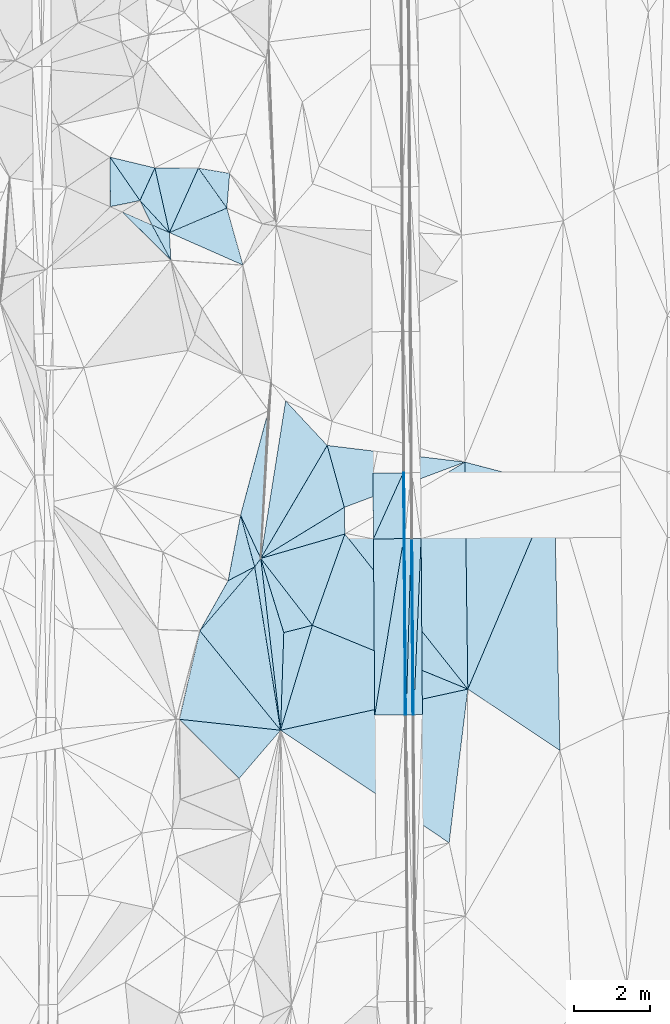
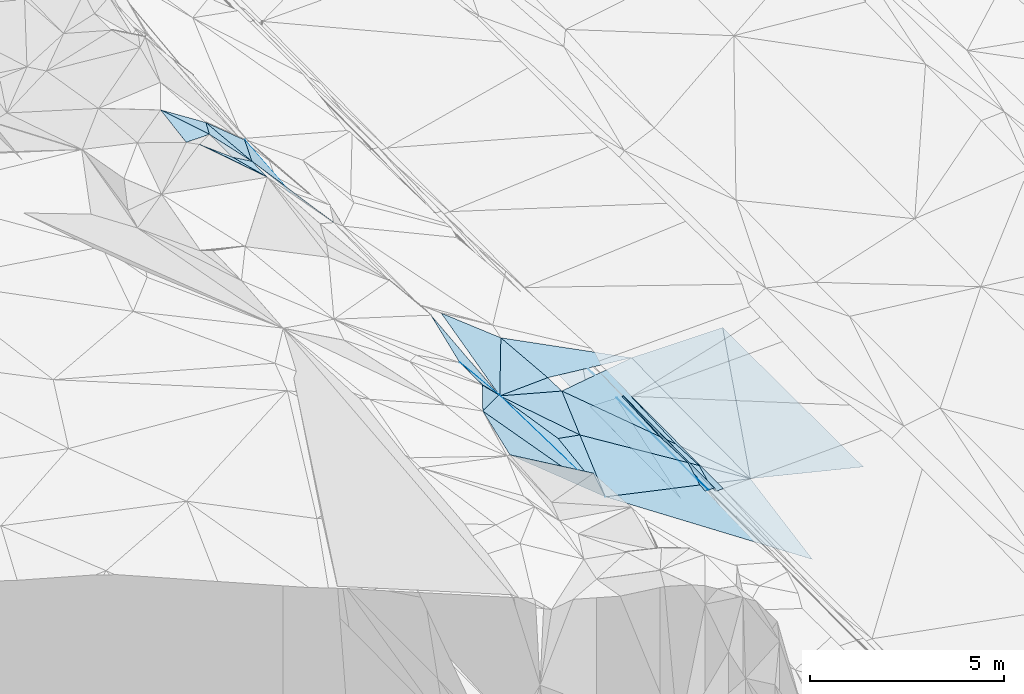
# One storey, part 54 of 275: 46 plates.
"""IFC2X3 building model written with IfcOpenShell, lengths in millimetres."""

from ifc_helpers import new_model, si_unit, frame, origin_with_axes, place, context, subcontext, project, spatial, polyline, outline, extrude, material, type_object, element, save


model = new_model("IFC2X3")

# Units and contexts
model_context = context("Model", 3, precision=1e-05, world=origin_with_axes())
body_context = subcontext(model_context, "Body", "Model", "MODEL_VIEW")
ifc_project = project(units=[si_unit("LENGTHUNIT", "METRE", prefix="MILLI"), si_unit("AREAUNIT", "SQUARE_METRE"), si_unit("VOLUMEUNIT", "CUBIC_METRE"), si_unit("MASSUNIT", "GRAM", prefix="KILO"), si_unit("TIMEUNIT", "SECOND"), si_unit("PLANEANGLEUNIT", "RADIAN"), si_unit("SOLIDANGLEUNIT", "STERADIAN"), si_unit("THERMODYNAMICTEMPERATUREUNIT", "DEGREE_CELSIUS"), si_unit("LUMINOUSINTENSITYUNIT", "LUMEN")], contexts=[model_context])

# Site, building, storey
site_placement = place(None, origin_with_axes())
site = spatial("IfcSite", under=ifc_project, at=site_placement, CompositionType="ELEMENT")
building_placement = place(site_placement, origin_with_axes())
building = spatial("IfcBuilding", under=site, at=building_placement, Name="Undefined", CompositionType="ELEMENT")
storey_placement = place(building_placement, origin_with_axes())
storey = spatial("IfcBuildingStorey", under=building, at=storey_placement, Name="Undefined", CompositionType="ELEMENT", Elevation=0.0)

# Plates
ifc_material = material()
plate_type_1 = type_object("IfcPlateType", PredefinedType="NOTDEFINED")
plate_1_placement = place(storey_placement, frame((-93950.5785130084, 36996.4624813921, 41676.0468128208), z_axis=(-0.970179685272548, -0.00209082154072468, -0.242377818188352), x_axis=(-0.0136848701070664, 0.998840273817399, 0.0461609329469833)))
element("IfcPlate", 1, at=plate_1_placement, inside=storey, type_object=plate_type_1, material=ifc_material, Name="00_PR", context=body_context, shape_type="SweptSolid", body=[
    extrude(outline(polyline([(0.0, 0.0), (4660.52099609375, -8.84756445884705e-09), (4655.595703125, 123.593780517578), (0.0, 0.0)])), frame((-8.85201319254618e-08, 2.18876761149539e-07, -0.5000001331573), z_axis=(0.0, 0.0, 1.0), x_axis=(1.0, 0.0, 0.0)), (0.0, 0.0, 1.0), 1.0),
])
plate_2_placement = place(storey_placement, frame((-93980.5688276247, 36995.7437087073, 41796.0467650642), z_axis=(-0.970155847921979, -0.00208608373127504, -0.242473254189927), x_axis=(-0.00725548811011348, 0.99976498987344, 0.0204284829501307)))
element("IfcPlate", 2, at=plate_2_placement, inside=storey, type_object=plate_type_1, material=ifc_material, Name="00_PR", context=body_context, shape_type="SweptSolid", body=[
    extrude(outline(polyline([(0.0, 0.0), (4656.92919921875, -3.04135028272867e-09), (-1.9504063129425, 123.677536010742), (0.0, 0.0)])), frame((-8.85201319254618e-08, 2.18876761149539e-07, -0.5000001331573), z_axis=(0.0, 0.0, 1.0), x_axis=(1.0, 0.0, 0.0)), (0.0, 0.0, 1.0), 1.0),
])
plate_type_2 = type_object("IfcPlateType", PredefinedType="NOTDEFINED")
plate_3_placement = place(storey_placement, frame((-94213.8776256981, 41650.2157978463, 41891.4022104386), z_axis=(-0.020135283573241, 0.0208413177685914, -0.99958001672157), x_axis=(0.0104989039006827, 0.999731988309625, 0.0206330939843829)))
element("IfcPlate", 3, at=plate_3_placement, inside=storey, type_object=plate_type_2, material=ifc_material, Name="00_PR", context=body_context, shape_type="SweptSolid", body=[
    extrude(outline(polyline([(0.0, 0.0), (1741.91040039063, 2.69210431724787e-09), (0.508228659629822, 30.0019760131836), (0.0, 0.0)])), frame((-8.85201319254618e-08, 2.18876761149539e-07, -0.5000001331573), z_axis=(0.0, 0.0, 1.0), x_axis=(1.0, 0.0, 0.0)), (0.0, 0.0, 1.0), 1.0),
])
plate_4_placement = place(storey_placement, frame((-94195.5894751698, 43391.6593004186, 41927.3432111175), z_axis=(-0.0201297745823609, 0.0208413569772079, -0.999580126860579), x_axis=(-0.0104989038900148, -0.999731988310175, -0.0206330939631766)))
element("IfcPlate", 4, at=plate_4_placement, inside=storey, type_object=plate_type_2, material=ifc_material, Name="00_PR", context=body_context, shape_type="SweptSolid", body=[
    extrude(outline(polyline([(0.0, 0.0), (1741.91040039063, 2.69210431724787e-09), (0.500202655792236, 30.0012283325195), (0.0, 0.0)])), frame((-8.85201319254618e-08, 2.18876761149539e-07, -0.5000001331573), z_axis=(0.0, 0.0, 1.0), x_axis=(1.0, 0.0, 0.0)), (0.0, 0.0, 1.0), 1.0),
])
plate_5_placement = place(storey_placement, frame((-94183.8780499656, 41650.4212178136, 41890.802205341), z_axis=(-0.0201311603663286, 0.0202781652050901, -0.999591682837658), x_axis=(0.00081387610926095, -0.999793629852607, -0.0202986529559961)))
element("IfcPlate", 5, at=plate_5_placement, inside=storey, type_object=plate_type_2, material=ifc_material, Name="00_PR", context=body_context, shape_type="SweptSolid", body=[
    extrude(outline(polyline([(0.0, 0.0), (4657.15625, -2.91038304567337e-11), (0.169063434004784, 30.0058040618896), (0.0, 0.0)])), frame((-8.85201319254618e-08, 2.18876761149539e-07, -0.5000001331573), z_axis=(0.0, 0.0, 1.0), x_axis=(1.0, 0.0, 0.0)), (0.0, 0.0, 1.0), 1.0),
])
plate_6_placement = place(storey_placement, frame((-94183.8780499656, 41650.4212178136, 41890.802205341), z_axis=(-0.0201474347669718, 0.0202780407636557, -0.999591357473192), x_axis=(0.00725548812216576, -0.999764989873477, -0.0204284829440498)))
element("IfcPlate", 6, at=plate_6_placement, inside=storey, type_object=plate_type_2, material=ifc_material, Name="00_PR", context=body_context, shape_type="SweptSolid", body=[
    extrude(outline(polyline([(0.0, 0.0), (4657.06005859375, -1.55559973791242e-08), (4657.0595703125, 30.0057888031006), (0.0, 0.0)])), frame((-8.85201319254618e-08, 2.18876761149539e-07, -0.5000001331573), z_axis=(0.0, 0.0, 1.0), x_axis=(1.0, 0.0, 0.0)), (0.0, 0.0, 1.0), 1.0),
])
plate_type_3 = type_object("IfcPlateType", PredefinedType="NOTDEFINED")
plate_7_placement = place(storey_placement, frame((-94225.5882216855, 43391.4616175226, 41927.9432097859), z_axis=(-0.0201291618125132, 0.020838557269471, -0.999580197570787), x_axis=(-0.411310993862948, -0.911432053981367, -0.0107180829806612)))
element("IfcPlate", 7, at=plate_7_placement, inside=storey, type_object=plate_type_3, material=ifc_material, Name="00_PR", context=body_context, shape_type="SweptSolid", body=[
    extrude(outline(polyline([(0.0, 0.0), (1916.48083496094, -5.3987605497241e-09), (333.668701171875, 727.270202636719), (0.0, 0.0)])), frame((-8.85201319254618e-08, 2.18876761149539e-07, -0.5000001331573), z_axis=(0.0, 0.0, 1.0), x_axis=(1.0, 0.0, 0.0)), (0.0, 0.0, 1.0), 1.0),
])
plate_8_placement = place(storey_placement, frame((-94980.0641760851, 36988.1104912917, 41812.2682041241), z_axis=(-0.0201474347669718, 0.0202780407636557, -0.999591357473192), x_axis=(0.162145343856178, 0.986624766843307, 0.0167468479766436)))
element("IfcPlate", 8, at=plate_8_placement, inside=storey, type_object=plate_type_3, material=ifc_material, Name="00_PR", context=body_context, shape_type="SweptSolid", body=[
    extrude(outline(polyline([(0.0, 0.0), (4725.30712890625, -1.06228981167078e-08), (135.478302001953, 788.607238769531), (0.0, 0.0)])), frame((-8.85201319254618e-08, 2.18876761149539e-07, -0.5000001331573), z_axis=(0.0, 0.0, 1.0), x_axis=(1.0, 0.0, 0.0)), (0.0, 0.0, 1.0), 1.0),
])
plate_9_placement = place(storey_placement, frame((-95013.8578508624, 41644.7195649811, 41907.4022094832), z_axis=(-0.020135283573241, 0.0208413177685914, -0.99958001672157), x_axis=(0.411310993878784, 0.911432053974247, 0.0107180829784441)))
element("IfcPlate", 9, at=plate_9_placement, inside=storey, type_object=plate_type_3, material=ifc_material, Name="00_PR", context=body_context, shape_type="SweptSolid", body=[
    extrude(outline(polyline([(0.0, 0.0), (1916.48083496094, -5.3987605497241e-09), (333.878601074219, 727.17236328125), (0.0, 0.0)])), frame((-8.85201319254618e-08, 2.18876761149539e-07, -0.5000001331573), z_axis=(0.0, 0.0, 1.0), x_axis=(1.0, 0.0, 0.0)), (0.0, 0.0, 1.0), 1.0),
])
plate_10_placement = place(storey_placement, frame((-94213.8776239783, 41650.2155149351, 41891.4022045246), z_axis=(-0.0201316304963867, 0.0202754497270247, -0.999591728453134), x_axis=(-0.162145343868325, -0.986624766841396, -0.01674684797159)))
element("IfcPlate", 10, at=plate_10_placement, inside=storey, type_object=plate_type_3, material=ifc_material, Name="00_PR", context=body_context, shape_type="SweptSolid", body=[
    extrude(outline(polyline([(0.0, 0.0), (4725.30712890625, -1.06228981167078e-08), (134.867828369141, 788.711120605469), (0.0, 0.0)])), frame((-8.85201319254618e-08, 2.18876761149539e-07, -0.5000001331573), z_axis=(0.0, 0.0, 1.0), x_axis=(1.0, 0.0, 0.0)), (0.0, 0.0, 1.0), 1.0),
])
plate_type_4 = type_object("IfcPlateType", PredefinedType="NOTDEFINED")
plate_11_placement = place(storey_placement, frame((-99602.1503594597, 39215.5463173642, 44839.7314416083), z_axis=(-0.772565921785493, 0.338620914935313, -0.537101268350861), x_axis=(0.485372854095596, 0.860320502442921, -0.155762080056269)))
element("IfcPlate", 11, at=plate_11_placement, inside=storey, type_object=plate_type_4, material=ifc_material, Name="00", context=body_context, shape_type="SweptSolid", body=[
    extrude(outline(polyline([(0.0, 0.0), (1540.8115234375, 1.07684172689915e-09), (2317.35034179688, 794.976318359375), (0.0, 0.0)])), frame((-8.85201319254618e-08, 2.18876761149539e-07, -0.5000001331573), z_axis=(0.0, 0.0, 1.0), x_axis=(1.0, 0.0, 0.0)), (0.0, 0.0, 1.0), 1.0),
])
plate_type_5 = type_object("IfcPlateType", PredefinedType="NOTDEFINED")
plate_12_placement = place(storey_placement, frame((-93753.8615539523, 41653.3765346723, 41778.3023714992), z_axis=(0.0324702506987195, 0.0206546735907928, -0.999259259290811), x_axis=(0.00725548812216576, -0.999764989873477, -0.0204284829440498)))
element("IfcPlate", 12, at=plate_12_placement, inside=storey, type_object=plate_type_5, material=ifc_material, Name="00_PR", context=body_context, shape_type="SweptSolid", body=[
    extrude(outline(polyline([(0.0, 0.0), (4656.728515625, 3.33238858729601e-09), (4656.4814453125, 230.128311157227), (0.0, 0.0)])), frame((-8.85201319254618e-08, 2.18876761149539e-07, -0.5000001331573), z_axis=(0.0, 0.0, 1.0), x_axis=(1.0, 0.0, 0.0)), (0.0, 0.0, 1.0), 1.0),
])
plate_13_placement = place(storey_placement, frame((-93983.8786685902, 41652.6155986422, 41770.8023725597), z_axis=(0.0325137458013369, 0.0206528108191279, -0.999257883501169), x_axis=(0.999463375983165, 0.00330638811473462, 0.0325887690158541)))
element("IfcPlate", 13, at=plate_13_placement, inside=storey, type_object=plate_type_5, material=ifc_material, Name="00_PR", context=body_context, shape_type="SweptSolid", body=[
    extrude(outline(polyline([(0.0, 0.0), (230.140640258789, -1.06228981167078e-09), (15.2880506515503, 4657.2109375), (0.0, 0.0)])), frame((-8.85201319254618e-08, 2.18876761149539e-07, -0.5000001331573), z_axis=(0.0, 0.0, 1.0), x_axis=(1.0, 0.0, 0.0)), (0.0, 0.0, 1.0), 1.0),
])
plate_type_6 = type_object("IfcPlateType", PredefinedType="NOTDEFINED")
plate_14_placement = place(storey_placement, frame((-94013.8721249891, 41651.5898474304, 41890.8021053352), z_axis=(-0.00015613799379114, 0.0204278877646966, -0.999791316736848), x_axis=(0.00725548812216576, -0.999764989873477, -0.0204284829440498)))
element("IfcPlate", 14, at=plate_14_placement, inside=storey, type_object=plate_type_6, material=ifc_material, Name="00_PR", context=body_context, shape_type="SweptSolid", body=[
    extrude(outline(polyline([(0.0, 0.0), (4656.92919921875, -3.04135028272867e-09), (4656.9951171875, 169.999923706055), (0.0, 0.0)])), frame((-8.85201319254618e-08, 2.18876761149539e-07, -0.5000001331573), z_axis=(0.0, 0.0, 1.0), x_axis=(1.0, 0.0, 0.0)), (0.0, 0.0, 1.0), 1.0),
])
plate_15_placement = place(storey_placement, frame((-94150.0787969721, 36994.4556287744, 41795.6681059385), z_axis=(-0.000140417984787431, 0.0204274278473883, -0.99979132846526), x_axis=(-0.00725548811011348, 0.99976498987344, 0.0204284829501307)))
element("IfcPlate", 15, at=plate_15_placement, inside=storey, type_object=plate_type_6, material=ifc_material, Name="00_PR", context=body_context, shape_type="SweptSolid", body=[
    extrude(outline(polyline([(0.0, 0.0), (4657.06005859375, -1.55559973791242e-08), (4656.9951171875, 169.999923706055), (0.0, 0.0)])), frame((-8.85201319254618e-08, 2.18876761149539e-07, -0.5000001331573), z_axis=(0.0, 0.0, 1.0), x_axis=(1.0, 0.0, 0.0)), (0.0, 0.0, 1.0), 1.0),
])
plate_type_7 = type_object("IfcPlateType", PredefinedType="NOTDEFINED")
plate_16_placement = place(storey_placement, frame((-100405.86991803, 49739.0135240849, 46609.6032710821), z_axis=(-0.608535526301397, 0.0116429874146828, -0.793441210218592), x_axis=(-0.598082811224722, 0.650415691934022, 0.468248201922358)))
element("IfcPlate", 16, at=plate_16_placement, inside=storey, type_object=plate_type_7, material=ifc_material, Name="00", context=body_context, shape_type="SweptSolid", body=[
    extrude(outline(polyline([(0.0, 0.0), (1302.72790527344, 5.82076609134674e-11), (1492.40686035156, 974.228881835938), (0.0, 0.0)])), frame((-8.85201319254618e-08, 2.18876761149539e-07, -0.5000001331573), z_axis=(0.0, 0.0, 1.0), x_axis=(1.0, 0.0, 0.0)), (0.0, 0.0, 1.0), 1.0),
])
plate_type_8 = type_object("IfcPlateType", PredefinedType="NOTDEFINED")
plate_17_placement = place(storey_placement, frame((-98525.9534439738, 42271.4719195884, 44139.6603795784), z_axis=(-0.732753729225391, -0.0415330979365877, -0.679225274914054), x_axis=(0.25769535006146, -0.940734641474832, -0.220480023779757)))
element("IfcPlate", 17, at=plate_17_placement, inside=storey, type_object=plate_type_8, material=ifc_material, Name="00", context=body_context, shape_type="SweptSolid", body=[
    extrude(outline(polyline([(0.0, 0.0), (1451.37866210938, -2.2846506908536e-09), (1441.93933105469, 1111.26550292969), (0.0, 0.0)])), frame((-8.85201319254618e-08, 2.18876761149539e-07, -0.5000001331573), z_axis=(0.0, 0.0, 1.0), x_axis=(1.0, 0.0, 0.0)), (0.0, 0.0, 1.0), 1.0),
])
plate_type_9 = type_object("IfcPlateType", PredefinedType="NOTDEFINED")
plate_18_placement = place(storey_placement, frame((-100405.88402384, 49739.0082591575, 46609.6144608093), z_axis=(-0.636753251418782, 0.00111473213475843, -0.77106682860818), x_axis=(-0.215741597249858, 0.959800922046216, 0.179548748966161)))
element("IfcPlate", 18, at=plate_18_placement, inside=storey, type_object=plate_type_9, material=ifc_material, Name="00", context=body_context, shape_type="SweptSolid", body=[
    extrude(outline(polyline([(0.0, 0.0), (1782.24572753906, -2.40106601268053e-09), (1358.39855957031, 1430.47314453125), (0.0, 0.0)])), frame((-8.85201319254618e-08, 2.18876761149539e-07, -0.5000001331573), z_axis=(0.0, 0.0, 1.0), x_axis=(1.0, 0.0, 0.0)), (0.0, 0.0, 1.0), 1.0),
])
plate_type_10 = type_object("IfcPlateType", PredefinedType="NOTDEFINED")
plate_19_placement = place(storey_placement, frame((-97468.2220157343, 36587.781176388, 42985.5196820596), z_axis=(-0.259570074999627, 0.0993513338899529, -0.960600171048796), x_axis=(-0.113523928559308, 0.984658279731703, 0.132515620966985)))
element("IfcPlate", 19, at=plate_19_placement, inside=storey, type_object=plate_type_10, material=ifc_material, Name="00", context=body_context, shape_type="SweptSolid", body=[
    extrude(outline(polyline([(0.0, 0.0), (4610.77734375, -1.37370079755783e-08), (2563.76416015625, 391.875732421875), (0.0, 0.0)])), frame((-8.85201319254618e-08, 2.18876761149539e-07, -0.5000001331573), z_axis=(0.0, 0.0, 1.0), x_axis=(1.0, 0.0, 0.0)), (0.0, 0.0, 1.0), 1.0),
])
plate_type_11 = type_object("IfcPlateType", PredefinedType="NOTDEFINED")
plate_20_placement = place(storey_placement, frame((-101184.948108172, 50586.2873270622, 47219.5645824686), z_axis=(-0.486582377466823, -0.070098330524117, -0.870817899446529), x_axis=(-0.550702514058618, 0.798412240717518, 0.243443288841468)))
element("IfcPlate", 20, at=plate_20_placement, inside=storey, type_object=plate_type_11, material=ifc_material, Name="00", context=body_context, shape_type="SweptSolid", body=[
    extrude(outline(polyline([(0.0, 0.0), (1437.70654296875, 6.28642737865448e-09), (401.333648681641, 907.76171875), (0.0, 0.0)])), frame((-8.85201319254618e-08, 2.18876761149539e-07, -0.5000001331573), z_axis=(0.0, 0.0, 1.0), x_axis=(1.0, 0.0, 0.0)), (0.0, 0.0, 1.0), 1.0),
])
plate_type_12 = type_object("IfcPlateType", PredefinedType="NOTDEFINED")
plate_21_placement = place(storey_placement, frame((-100866.297406921, 49939.9729684774, 46779.5271561575), z_axis=(-0.316385608843126, 0.074878604908276, -0.945670841806997), x_axis=(0.86823434398444, -0.378772150786415, -0.320469626820612)))
element("IfcPlate", 21, at=plate_21_placement, inside=storey, type_object=plate_type_12, material=ifc_material, Name="00", context=body_context, shape_type="SweptSolid", body=[
    extrude(outline(polyline([(0.0, 0.0), (530.471496582031, 1.74622982740402e-10), (860.55517578125, 652.644409179688), (0.0, 0.0)])), frame((-8.85201319254618e-08, 2.18876761149539e-07, -0.5000001331573), z_axis=(0.0, 0.0, 1.0), x_axis=(1.0, 0.0, 0.0)), (0.0, 0.0, 1.0), 1.0),
])
plate_type_13 = type_object("IfcPlateType", PredefinedType="NOTDEFINED")
plate_22_placement = place(storey_placement, frame((-101655.657473941, 50290.7311582777, 47249.5780910048), z_axis=(-0.53241500267624, -0.067335114786549, -0.843801070894047), x_axis=(0.80264765384784, -0.35678375573582, -0.477977086705631)))
element("IfcPlate", 22, at=plate_22_placement, inside=storey, type_object=plate_type_13, material=ifc_material, Name="00", context=body_context, shape_type="SweptSolid", body=[
    extrude(outline(polyline([(0.0, 0.0), (983.310729980469, -4.40923031419516e-09), (1828.61828613281, 672.276062011719), (0.0, 0.0)])), frame((-8.85201319254618e-08, 2.18876761149539e-07, -0.5000001331573), z_axis=(0.0, 0.0, 1.0), x_axis=(1.0, 0.0, 0.0)), (0.0, 0.0, 1.0), 1.0),
])
plate_type_14 = type_object("IfcPlateType", PredefinedType="NOTDEFINED")
plate_23_placement = place(storey_placement, frame((-100405.604317466, 49739.2750519236, 46609.579243459), z_axis=(-0.0773353083120374, 0.534698628494853, -0.841496658801451), x_axis=(-0.868234343983698, 0.378772150780406, 0.320469626829725)))
element("IfcPlate", 23, at=plate_23_placement, inside=storey, type_object=plate_type_14, material=ifc_material, Name="00", context=body_context, shape_type="SweptSolid", body=[
    extrude(outline(polyline([(0.0, 0.0), (530.471496582031, 1.74622982740402e-10), (1192.90100097656, 523.533264160156), (0.0, 0.0)])), frame((-8.85201319254618e-08, 2.18876761149539e-07, -0.5000001331573), z_axis=(0.0, 0.0, 1.0), x_axis=(1.0, 0.0, 0.0)), (0.0, 0.0, 1.0), 1.0),
])
plate_type_15 = type_object("IfcPlateType", PredefinedType="NOTDEFINED")
plate_24_placement = place(storey_placement, frame((-98525.976075918, 42271.4593291351, 44139.6876463612), z_axis=(-0.778016569987856, -0.0667130044341407, -0.624691597401232), x_axis=(0.388660819200202, -0.832338106926882, -0.39516584287613)))
element("IfcPlate", 24, at=plate_24_placement, inside=storey, type_object=plate_type_15, material=ifc_material, Name="00", context=body_context, shape_type="SweptSolid", body=[
    extrude(outline(polyline([(0.0, 0.0), (1374.10656738281, 5.16592990607023e-10), (1408.26049804688, 351.144592285156), (0.0, 0.0)])), frame((-8.85201319254618e-08, 2.18876761149539e-07, -0.5000001331573), z_axis=(0.0, 0.0, 1.0), x_axis=(1.0, 0.0, 0.0)), (0.0, 0.0, 1.0), 1.0),
])
plate_type_16 = type_object("IfcPlateType", PredefinedType="NOTDEFINED")
plate_25_placement = place(storey_placement, frame((-101976.544969999, 51734.2893371752, 47569.5157652047), z_axis=(-0.183133861079745, 0.168975512687857, -0.96845715704821), x_axis=(0.550702514081441, -0.798412240700273, -0.243443288846396)))
element("IfcPlate", 25, at=plate_25_placement, inside=storey, type_object=plate_type_16, material=ifc_material, Name="00", context=body_context, shape_type="SweptSolid", body=[
    extrude(outline(polyline([(0.0, 0.0), (1437.70654296875, 6.28642737865448e-09), (1105.44116210938, 735.730773925781), (0.0, 0.0)])), frame((-8.85201319254618e-08, 2.18876761149539e-07, -0.5000001331573), z_axis=(0.0, 0.0, 1.0), x_axis=(1.0, 0.0, 0.0)), (0.0, 0.0, 1.0), 1.0),
])
plate_type_17 = type_object("IfcPlateType", PredefinedType="NOTDEFINED")
plate_26_placement = place(storey_placement, frame((-96626.7172636025, 39360.8251726172, 42959.5456123844), z_axis=(-0.417322743732877, 0.00521624135214632, -0.908743373229989), x_axis=(-0.587891846576746, 0.760997636621141, 0.274346083962614)))
element("IfcPlate", 26, at=plate_26_placement, inside=storey, type_object=plate_type_17, material=ifc_material, Name="00", context=body_context, shape_type="SweptSolid", body=[
    extrude(outline(polyline([(0.0, 0.0), (2321.884765625, 8.87666828930378e-10), (1227.70092773438, 2279.11181640625), (0.0, 0.0)])), frame((-8.85201319254618e-08, 2.18876761149539e-07, -0.5000001331573), z_axis=(0.0, 0.0, 1.0), x_axis=(1.0, 0.0, 0.0)), (0.0, 0.0, 1.0), 1.0),
])
plate_type_18 = type_object("IfcPlateType", PredefinedType="NOTDEFINED")
plate_27_placement = place(storey_placement, frame((-99640.0886888829, 51444.3736954838, 45979.704746539), z_axis=(-0.79499853982599, 0.138894643180465, -0.590496062451152), x_axis=(0.415598475119519, -0.584372363804399, -0.696984108785838)))
element("IfcPlate", 27, at=plate_27_placement, inside=storey, type_object=plate_type_18, material=ifc_material, Name="00", context=body_context, shape_type="SweptSolid", body=[
    extrude(outline(polyline([(0.0, 0.0), (1807.78869628906, 6.05359673500061e-09), (239.131927490234, 1958.14099121094), (0.0, 0.0)])), frame((-8.85201319254618e-08, 2.18876761149539e-07, -0.5000001331573), z_axis=(0.0, 0.0, 1.0), x_axis=(1.0, 0.0, 0.0)), (0.0, 0.0, 1.0), 1.0),
])
plate_type_19 = type_object("IfcPlateType", PredefinedType="NOTDEFINED")
plate_28_placement = place(storey_placement, frame((-98888.8039558156, 50387.8889992374, 44719.7399294807), z_axis=(-0.853988008944963, 0.0130158957795944, -0.520129855935297), x_axis=(-0.415598475138861, 0.584372363799542, 0.696984108778377)))
element("IfcPlate", 28, at=plate_28_placement, inside=storey, type_object=plate_type_19, material=ifc_material, Name="00", context=body_context, shape_type="SweptSolid", body=[
    extrude(outline(polyline([(0.0, 0.0), (1807.78869628906, 6.05359673500061e-09), (436.057586669922, 818.262634277344), (0.0, 0.0)])), frame((-8.85201319254618e-08, 2.18876761149539e-07, -0.5000001331573), z_axis=(0.0, 0.0, 1.0), x_axis=(1.0, 0.0, 0.0)), (0.0, 0.0, 1.0), 1.0),
])
plate_type_20 = type_object("IfcPlateType", PredefinedType="NOTDEFINED")
plate_29_placement = place(storey_placement, frame((-97991.9286828822, 41127.7647350316, 43596.704135629), z_axis=(-0.806038825620768, -0.0132974486103588, -0.591713266246708), x_axis=(0.11352392816766, -0.984658279787137, -0.132515620890593)))
element("IfcPlate", 29, at=plate_29_placement, inside=storey, type_object=plate_type_20, material=ifc_material, Name="00", context=body_context, shape_type="SweptSolid", body=[
    extrude(outline(polyline([(0.0, 0.0), (4610.77734375, -1.37370079755783e-08), (170.520278930664, 308.855682373047), (0.0, 0.0)])), frame((-8.85201319254618e-08, 2.18876761149539e-07, -0.5000001331573), z_axis=(0.0, 0.0, 1.0), x_axis=(1.0, 0.0, 0.0)), (0.0, 0.0, 1.0), 1.0),
])
plate_type_21 = type_object("IfcPlateType", PredefinedType="NOTDEFINED")
plate_30_placement = place(storey_placement, frame((-97991.852256333, 41127.7981745605, 43596.6223440139), z_axis=(-0.653189580687692, 0.0535816736762087, -0.755296217339326), x_axis=(-0.38866081919298, 0.832338106926508, 0.395165842884021)))
element("IfcPlate", 30, at=plate_30_placement, inside=storey, type_object=plate_type_21, material=ifc_material, Name="00", context=body_context, shape_type="SweptSolid", body=[
    extrude(outline(polyline([(0.0, 0.0), (1374.10656738281, 5.16592990607023e-10), (3214.4296875, 2232.44506835938), (0.0, 0.0)])), frame((-8.85201319254618e-08, 2.18876761149539e-07, -0.5000001331573), z_axis=(0.0, 0.0, 1.0), x_axis=(1.0, 0.0, 0.0)), (0.0, 0.0, 1.0), 1.0),
])
plate_type_22 = type_object("IfcPlateType", PredefinedType="NOTDEFINED")
plate_31_placement = place(storey_placement, frame((-96235.5825426731, 44114.9416529231, 42999.5331166571), z_axis=(-0.357199911746024, 0.0233822920339932, -0.933735236278395), x_axis=(-0.49944090563772, -0.849547667654879, 0.169786754954352)))
element("IfcPlate", 31, at=plate_31_placement, inside=storey, type_object=plate_type_22, material=ifc_material, Name="00", context=body_context, shape_type="SweptSolid", body=[
    extrude(outline(polyline([(0.0, 0.0), (3516.17529296875, -1.58906914293766e-08), (-373.522338867188, 1629.19641113281), (0.0, 0.0)])), frame((-8.85201319254618e-08, 2.18876761149539e-07, -0.5000001331573), z_axis=(0.0, 0.0, 1.0), x_axis=(1.0, 0.0, 0.0)), (0.0, 0.0, 1.0), 1.0),
])
plate_type_23 = type_object("IfcPlateType", PredefinedType="NOTDEFINED")
plate_32_placement = place(storey_placement, frame((-98151.8815449293, 40906.1576437955, 43819.6070616894), z_axis=(-0.61601635832866, 0.0542730650618408, -0.785861489500719), x_axis=(0.153557317141866, -0.970211857646001, -0.187374228845079)))
element("IfcPlate", 32, at=plate_32_placement, inside=storey, type_object=plate_type_23, material=ifc_material, Name="00", context=body_context, shape_type="SweptSolid", body=[
    extrude(outline(polyline([(0.0, 0.0), (4450.98583984375, -3.94356902688742e-09), (1226.57995605469, 2120.7548828125), (0.0, 0.0)])), frame((-8.85201319254618e-08, 2.18876761149539e-07, -0.5000001331573), z_axis=(0.0, 0.0, 1.0), x_axis=(1.0, 0.0, 0.0)), (0.0, 0.0, 1.0), 1.0),
])
plate_type_24 = type_object("IfcPlateType", PredefinedType="NOTDEFINED")
plate_33_placement = place(storey_placement, frame((-99602.0686675432, 39215.4085602881, 44839.6047342585), z_axis=(-0.60918171727886, 0.0631067917521714, -0.790515760859913), x_axis=(0.55286136695901, -0.680856163662049, -0.480394830662874)))
element("IfcPlate", 33, at=plate_33_placement, inside=storey, type_object=plate_type_24, material=ifc_material, Name="00", context=body_context, shape_type="SweptSolid", body=[
    extrude(outline(polyline([(0.0, 0.0), (3859.32543945313, -2.81579559668899e-09), (1182.62634277344, 2101.0224609375), (0.0, 0.0)])), frame((-8.85201319254618e-08, 2.18876761149539e-07, -0.5000001331573), z_axis=(0.0, 0.0, 1.0), x_axis=(1.0, 0.0, 0.0)), (0.0, 0.0, 1.0), 1.0),
])
plate_type_25 = type_object("IfcPlateType", PredefinedType="NOTDEFINED")
plate_34_placement = place(storey_placement, frame((-95784.965398504, 42477.2993653637, 42579.5448268288), z_axis=(-0.413812237946844, -0.00933834867042202, -0.910314356126242), x_axis=(0.0225608886650078, -0.999745470758755, -4.4947101919241e-11)))
element("IfcPlate", 34, at=plate_34_placement, inside=storey, type_object=plate_type_25, material=ifc_material, Name="00", context=body_context, shape_type="SweptSolid", body=[
    extrude(outline(polyline([(0.0, 0.0), (703.846557617188, -1.94995664060116e-09), (1299.40246582031, 2457.0107421875), (0.0, 0.0)])), frame((-8.85201319254618e-08, 2.18876761149539e-07, -0.5000001331573), z_axis=(0.0, 0.0, 1.0), x_axis=(1.0, 0.0, 0.0)), (0.0, 0.0, 1.0), 1.0),
])
plate_type_26 = type_object("IfcPlateType", PredefinedType="NOTDEFINED")
plate_35_placement = place(storey_placement, frame((-98463.2340263936, 48881.2225842295, 44519.6764743021), z_axis=(-0.751912890944827, -0.126477038896554, -0.647016663667136), x_axis=(-0.652007113352726, 0.287866662631712, 0.70144102295398)))
element("IfcPlate", 35, at=plate_35_placement, inside=storey, type_object=plate_type_26, material=ifc_material, Name="00", context=body_context, shape_type="SweptSolid", body=[
    extrude(outline(polyline([(0.0, 0.0), (2979.58056640625, -1.10630935523659e-08), (851.428588867188, 1328.89782714844), (0.0, 0.0)])), frame((-8.85201319254618e-08, 2.18876761149539e-07, -0.5000001331573), z_axis=(0.0, 0.0, 1.0), x_axis=(1.0, 0.0, 0.0)), (0.0, 0.0, 1.0), 1.0),
])
plate_type_27 = type_object("IfcPlateType", PredefinedType="NOTDEFINED")
plate_36_placement = place(storey_placement, frame((-96235.6365314203, 44114.9787802046, 42999.5600758926), z_axis=(-0.46517720503653, 0.0976370485516825, -0.879816557393937), x_axis=(0.257562152640402, -0.935969635726211, -0.240047033986645)))
element("IfcPlate", 36, at=plate_36_placement, inside=storey, type_object=plate_type_27, material=ifc_material, Name="00", context=body_context, shape_type="SweptSolid", body=[
    extrude(outline(polyline([(0.0, 0.0), (1749.65710449219, 2.56113708019257e-09), (2200.27099609375, 2742.68041992188), (0.0, 0.0)])), frame((-8.85201319254618e-08, 2.18876761149539e-07, -0.5000001331573), z_axis=(0.0, 0.0, 1.0), x_axis=(1.0, 0.0, 0.0)), (0.0, 0.0, 1.0), 1.0),
])
plate_type_28 = type_object("IfcPlateType", PredefinedType="NOTDEFINED")
plate_37_placement = place(storey_placement, frame((-96626.6898055749, 39360.8732148627, 42959.5367352923), z_axis=(-0.362409346733524, 0.101298087291079, -0.926497794337013), x_axis=(0.85781407129879, -0.352449672402437, -0.374077862891149)))
element("IfcPlate", 37, at=plate_37_placement, inside=storey, type_object=plate_type_28, material=ifc_material, Name="00", context=body_context, shape_type="SweptSolid", body=[
    extrude(outline(polyline([(0.0, 0.0), (4787.7734375, 3.4315462471568e-08), (245.726760864258, 2887.66186523438), (0.0, 0.0)])), frame((-8.85201319254618e-08, 2.18876761149539e-07, -0.5000001331573), z_axis=(0.0, 0.0, 1.0), x_axis=(1.0, 0.0, 0.0)), (0.0, 0.0, 1.0), 1.0),
])
plate_type_29 = type_object("IfcPlateType", PredefinedType="NOTDEFINED")
plate_38_placement = place(storey_placement, frame((-92596.8487141097, 43674.7009432283, 41362.5447917376), z_axis=(-0.394445886324465, 0.124941084995967, -0.910385724867069), x_axis=(-0.881556566504766, -0.331079865490798, 0.336517670737993)))
element("IfcPlate", 38, at=plate_38_placement, inside=storey, type_object=plate_type_29, material=ifc_material, Name="00", context=body_context, shape_type="SweptSolid", body=[
    extrude(outline(polyline([(0.0, 0.0), (3616.45190429688, -1.58761395141482e-08), (3612.87377929688, 1749.65344238281), (0.0, 0.0)])), frame((-8.85201319254618e-08, 2.18876761149539e-07, -0.5000001331573), z_axis=(0.0, 0.0, 1.0), x_axis=(1.0, 0.0, 0.0)), (0.0, 0.0, 1.0), 1.0),
])
plate_type_30 = type_object("IfcPlateType", PredefinedType="NOTDEFINED")
plate_39_placement = place(storey_placement, frame((-95769.0646991747, 41773.6492267406, 42579.5358831444), z_axis=(-0.371218550944487, 0.0252325595276215, -0.928202620861609), x_axis=(0.814787695386717, 0.488272950370836, -0.312586847744049)))
element("IfcPlate", 39, at=plate_39_placement, inside=storey, type_object=plate_type_30, material=ifc_material, Name="00", context=body_context, shape_type="SweptSolid", body=[
    extrude(outline(polyline([(0.0, 0.0), (3893.31811523438, -6.95581547915936e-09), (1086.57531738281, 5308.57470703125), (0.0, 0.0)])), frame((-8.85201319254618e-08, 2.18876761149539e-07, -0.5000001331573), z_axis=(0.0, 0.0, 1.0), x_axis=(1.0, 0.0, 0.0)), (0.0, 0.0, 1.0), 1.0),
])
plate_type_31 = type_object("IfcPlateType", PredefinedType="NOTDEFINED")
plate_40_placement = place(storey_placement, frame((-96626.6836964967, 39360.85571683, 42959.5328196694), z_axis=(-0.350190355145868, 0.0663017358976836, -0.934329061401691), x_axis=(-0.915952941610554, -0.232912673569289, 0.326774991769228)))
element("IfcPlate", 40, at=plate_40_placement, inside=storey, type_object=plate_type_31, material=ifc_material, Name="00", context=body_context, shape_type="SweptSolid", body=[
    extrude(outline(polyline([(0.0, 0.0), (826.256591796875, 2.7648638933897e-10), (1046.90234375, 2072.47314453125), (0.0, 0.0)])), frame((-8.85201319254618e-08, 2.18876761149539e-07, -0.5000001331573), z_axis=(0.0, 0.0, 1.0), x_axis=(1.0, 0.0, 0.0)), (0.0, 0.0, 1.0), 1.0),
])
plate_type_32 = type_object("IfcPlateType", PredefinedType="NOTDEFINED")
plate_41_placement = place(storey_placement, frame((-97468.2705561328, 36587.781275638, 42985.5355350402), z_axis=(-0.356705985582949, 0.0995447139162629, -0.928898105165807), x_axis=(0.0326855962976246, 0.995027953076038, 0.094079883035534)))
element("IfcPlate", 41, at=plate_41_placement, inside=storey, type_object=plate_type_32, material=ifc_material, Name="00", context=body_context, shape_type="SweptSolid", body=[
    extrude(outline(polyline([(0.0, 0.0), (2593.54052734375, -7.5524440035224e-09), (2784.36474609375, 803.919250488281), (0.0, 0.0)])), frame((-8.85201319254618e-08, 2.18876761149539e-07, -0.5000001331573), z_axis=(0.0, 0.0, 1.0), x_axis=(1.0, 0.0, 0.0)), (0.0, 0.0, 1.0), 1.0),
])
plate_type_33 = type_object("IfcPlateType", PredefinedType="NOTDEFINED")
plate_42_placement = place(storey_placement, frame((-97468.2665724375, 36587.742190489, 42985.5314940198), z_axis=(-0.348724877131869, 0.0213751974829746, -0.936981355738697), x_axis=(0.919427558005961, 0.201707257664993, -0.337590206884713)))
element("IfcPlate", 42, at=plate_42_placement, inside=storey, type_object=plate_type_33, material=ifc_material, Name="00", context=body_context, shape_type="SweptSolid", body=[
    extrude(outline(polyline([(0.0, 0.0), (5382.26513671875, -1.93685991689563e-08), (4078.36645507813, 3880.10571289063), (0.0, 0.0)])), frame((-8.85201319254618e-08, 2.18876761149539e-07, -0.5000001331573), z_axis=(0.0, 0.0, 1.0), x_axis=(1.0, 0.0, 0.0)), (0.0, 0.0, 1.0), 1.0),
])
plate_type_34 = type_object("IfcPlateType", PredefinedType="NOTDEFINED")
plate_43_placement = place(storey_placement, frame((-90085.4192567014, 36053.1919405218, 41669.5127067899), z_axis=(0.221853114110209, 0.031927113554282, -0.974557261108702), x_axis=(-0.820478233231406, 0.546162310524651, -0.168885166180587)))
element("IfcPlate", 43, at=plate_43_placement, inside=storey, type_object=plate_type_34, material=ifc_material, Name="00", context=body_context, shape_type="SweptSolid", body=[
    extrude(outline(polyline([(0.0, 0.0), (2966.5126953125, -5.0931703299284e-11), (3915.13305664063, 5810.18359375), (0.0, 0.0)])), frame((-8.85201319254618e-08, 2.18876761149539e-07, -0.5000001331573), z_axis=(0.0, 0.0, 1.0), x_axis=(1.0, 0.0, 0.0)), (0.0, 0.0, 1.0), 1.0),
])
plate_type_35 = type_object("IfcPlateType", PredefinedType="NOTDEFINED")
plate_44_placement = place(storey_placement, frame((-92519.3810603527, 37673.3905980777, 41168.512152259), z_axis=(0.216541477827389, 0.0343242237527611, -0.975669839671239), x_axis=(-0.0128498785453982, 0.999395387279104, 0.0323069730339759)))
element("IfcPlate", 44, at=plate_44_placement, inside=storey, type_object=plate_type_35, material=ifc_material, Name="00", context=body_context, shape_type="SweptSolid", body=[
    extrude(outline(polyline([(0.0, 0.0), (6004.8955078125, 5.0931703299284e-10), (5371.53173828125, 2409.30688476563), (0.0, 0.0)])), frame((-8.85201319254618e-08, 2.18876761149539e-07, -0.5000001331573), z_axis=(0.0, 0.0, 1.0), x_axis=(1.0, 0.0, 0.0)), (0.0, 0.0, 1.0), 1.0),
])
plate_type_36 = type_object("IfcPlateType", PredefinedType="NOTDEFINED")
plate_45_placement = place(storey_placement, frame((-100142.742114667, 36876.8288240194, 45069.6707726509), z_axis=(-0.566665951172825, -0.495352916253662, -0.658418702757136), x_axis=(0.785932343450759, -0.085031573562285, -0.612437738072631)))
element("IfcPlate", 45, at=plate_45_placement, inside=storey, type_object=plate_type_36, material=ifc_material, Name="00", context=body_context, shape_type="SweptSolid", body=[
    extrude(outline(polyline([(0.0, 0.0), (3402.794921875, -8.68021743372083e-09), (1483.43640136719, 1665.17749023438), (0.0, 0.0)])), frame((-8.85201319254618e-08, 2.18876761149539e-07, -0.5000001331573), z_axis=(0.0, 0.0, 1.0), x_axis=(1.0, 0.0, 0.0)), (0.0, 0.0, 1.0), 1.0),
])
plate_type_37 = type_object("IfcPlateType", PredefinedType="NOTDEFINED")
plate_46_placement = place(storey_placement, frame((-92519.6895411851, 37673.3724459157, 41168.5418177074), z_axis=(-0.400413901619239, -0.00198915768239624, -0.916332227219895), x_axis=(-0.857814071294742, 0.352449672504273, 0.374077862804485)))
element("IfcPlate", 46, at=plate_46_placement, inside=storey, type_object=plate_type_37, material=ifc_material, Name="00", context=body_context, shape_type="SweptSolid", body=[
    extrude(outline(polyline([(0.0, 0.0), (4787.7734375, 3.4315462471568e-08), (4760.33251953125, 2588.59936523438), (0.0, 0.0)])), frame((-8.85201319254618e-08, 2.18876761149539e-07, -0.5000001331573), z_axis=(0.0, 0.0, 1.0), x_axis=(1.0, 0.0, 0.0)), (0.0, 0.0, 1.0), 1.0),
])

save(model, "model.ifc")
